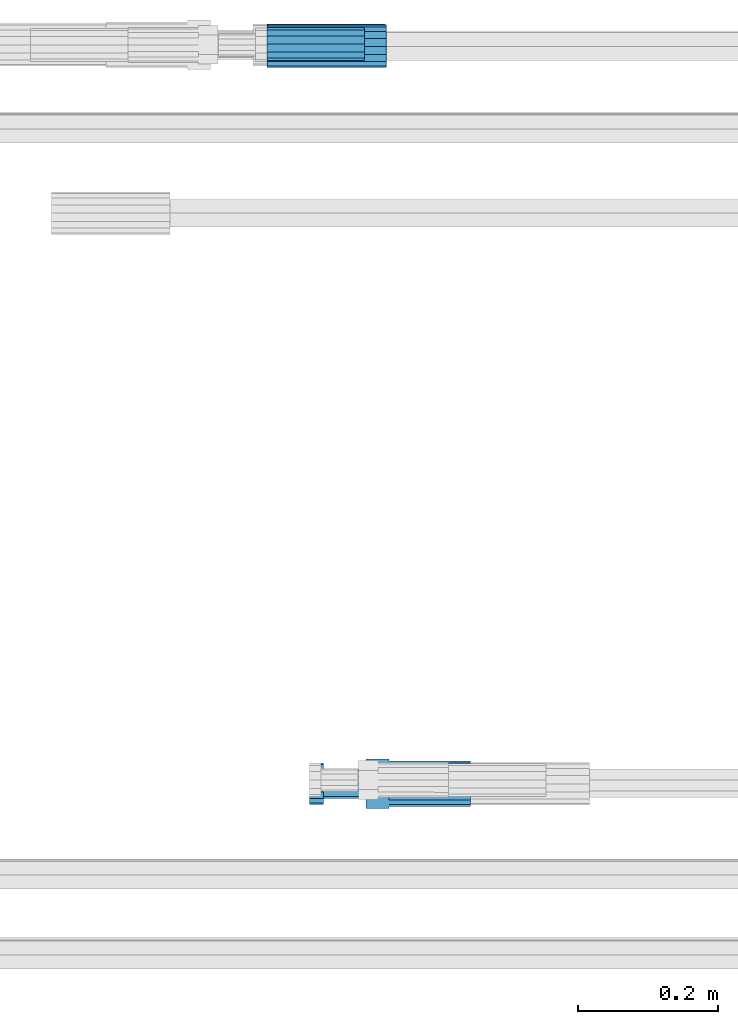
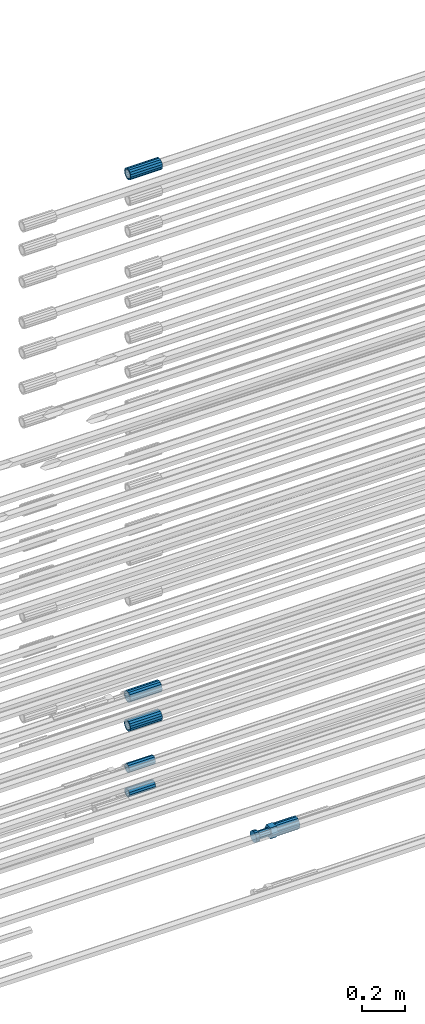
# One storey, part 11 of 119: 6 beams.
"""IFC2X3 building model written with IfcOpenShell, lengths in millimetres."""

from ifc_helpers import new_model, si_unit, frame, origin_with_axes, place, context, subcontext, project, spatial, faceted_brep, material, type_object, element, save


model = new_model("IFC2X3")

# Units and contexts
model_context = context("Model", 3, precision=1e-05, world=origin_with_axes())
body_context = subcontext(model_context, "Body", "Model", "MODEL_VIEW")
ifc_project = project(units=[si_unit("LENGTHUNIT", "METRE", prefix="MILLI"), si_unit("AREAUNIT", "SQUARE_METRE"), si_unit("VOLUMEUNIT", "CUBIC_METRE"), si_unit("MASSUNIT", "GRAM", prefix="KILO"), si_unit("TIMEUNIT", "SECOND"), si_unit("PLANEANGLEUNIT", "RADIAN"), si_unit("SOLIDANGLEUNIT", "STERADIAN"), si_unit("THERMODYNAMICTEMPERATUREUNIT", "DEGREE_CELSIUS"), si_unit("LUMINOUSINTENSITYUNIT", "LUMEN")], contexts=[model_context])

# Site, building, storey
site_placement = place(None, origin_with_axes())
site = spatial("IfcSite", under=ifc_project, at=site_placement, CompositionType="ELEMENT")
building_placement = place(site_placement, origin_with_axes())
building = spatial("IfcBuilding", under=site, at=building_placement, Name="Undefined", CompositionType="ELEMENT")
storey_placement = place(building_placement, origin_with_axes())
storey = spatial("IfcBuildingStorey", under=building, at=storey_placement, Name="Undefined", CompositionType="ELEMENT", Elevation=0.0)

# Beams
ifc_material = material(Name="STEEL/S275")
beam_type_1 = type_object("IfcBeamType", PredefinedType="NOTDEFINED")
beam_1_placement = place(storey_placement, frame((2032019.02007889, 6206399.98994599, 19251.9793079297), z_axis=(0.0, 0.0, 1.0), x_axis=(-0.99999999999998, 1.98000110685822e-07, 0.0)))
element("IfcBeam", 1, at=beam_1_placement, inside=storey, type_object=beam_type_1, material=ifc_material, Name="AG40N", context=body_context, shape_type="Brep", body=[
    faceted_brep([(1.62981450557709e-09, -23.4999999990687, 0.0), (7.45058059692383e-09, -21.7111690142192, 8.99306066057534), (170.000002125278, -21.711168999318, 8.99306066022245), (170.000002127141, -23.4999999844003, -3.66071617463604e-10), (4.65661287307739e-09, -16.6170093587134, 16.6170093578889), (170.000002122484, -16.6170093440451, 16.6170093575288), (1.86264514923096e-09, -8.99306066217832, 21.7111690140277), (170.000002118759, -8.99306064750999, 21.7111690136603), (2.3283064365387e-10, 9.31322574615479e-10, 23.5), (170.000002114102, 1.28056854009628e-08, 23.4999999996485), (-6.51925802230835e-09, 8.99306065868586, 21.7111690140241), (170.00000211224, 8.99306067335419, 21.7111690136639), (-7.45058059692383e-09, 16.6170093561523, 16.6170093578853), (170.000002109446, 16.6170093708206, 16.6170093575324), (-9.31322574615479e-09, 21.711169013055, 8.99306066057534), (170.000002108514, 21.7111690277234, 8.99306066022245), (-1.16415321826935e-09, 23.5000000009313, 0.0), (170.000002108514, 23.5000000144355, -3.66071617463604e-10), (-8.38190317153931e-09, 21.7111690151505, -8.99306066059444), (170.000002110377, 21.7111690300517, -8.9930606609546), (-5.58793544769287e-09, 16.6170093598776, -16.6170093579008), (170.000002113171, 16.6170093745459, -16.6170093582609), (-9.31322574615479e-10, 8.99306066334248, -21.7111690140396), (170.000002115965, 8.99306067801081, -21.7111690143961), (2.3283064365387e-10, 9.31322574615479e-10, -23.5), (170.00000211969, 1.7927959561348e-08, -23.5000000003843), (5.58793544769287e-09, -8.99306065752171, -21.7111690140396), (170.000002123415, -8.99306064285338, -21.7111690143961), (8.38190317153931e-09, -16.6170093549881, -16.6170093579008), (170.000002125278, -16.6170093403198, -16.6170093582646), (9.31322574615479e-09, -21.7111690121237, -8.99306066059444), (170.000002127141, -21.7111689972226, -8.9930606609546), (1.11758708953857e-08, -30.4999999990687, -9.54969436861575e-12), (1.30385160446167e-08, -28.1783257392235, -11.6718446871514), (170.000002129003, -28.1783257243223, -11.6718446875116), (170.000002129935, -30.4999999841675, -3.66071617463604e-10), (1.02445483207703e-08, -21.5667568228673, -21.5667568262129), (170.000002128072, -21.566756808199, -21.5667568265694), (7.45058059692383e-09, -11.6718446831219, -28.1783257416196), (170.000002125278, -11.6718446684536, -28.1783257419834), (3.72529029846191e-09, 3.95812094211578e-09, -30.5000000000277), (170.00000211969, 1.83936208486557e-08, -30.5000000003879), (-9.31322574615479e-10, 11.6718446905725, -28.1783257416232), (170.000002115965, 11.6718447052408, -28.1783257419797), (-6.51925802230835e-09, 21.5667568286881, -21.5667568262093), (170.000002110377, 21.5667568433564, -21.5667568265694), (-9.31322574615479e-09, 28.178325742716, -11.6718446871478), (170.000002108514, 28.1783257573843, -11.6718446875079), (-1.21071934700012e-08, 30.5, -5.91171556152403e-12), (170.000002106652, 30.5000000144355, -3.62433638656512e-10), (-1.21071934700012e-08, 28.1783257401548, 11.6718446871359), (170.00000210572, 28.1783257548232, 11.6718446867794), (-1.02445483207703e-08, 21.5667568240315, 21.5667568261974), (170.000002107583, 21.566756838467, 21.5667568258409), (-7.45058059692383e-09, 11.671844684286, 28.1783257416041), (170.000002110377, 11.6718446989544, 28.178325741244), (-2.79396772384644e-09, -2.56113708019257e-09, 30.5000000000159), (170.000002114102, 1.18743628263474e-08, 30.4999999996558), (1.86264514923096e-09, -11.6718446896411, 28.1783257416114), (170.000002118759, -11.67184467474, 28.178325741244), (7.45058059692383e-09, -21.5667568275239, 21.5667568261974), (170.000002123415, -21.5667568126228, 21.5667568258373), (1.02445483207703e-08, -28.1783257415518, 11.6718446871359), (170.000002127141, -28.1783257271163, 11.6718446867794)], [[[0, 1, 2, 3]], [[1, 4, 5, 2]], [[4, 6, 7, 5]], [[6, 8, 9, 7]], [[8, 10, 11, 9]], [[10, 12, 13, 11]], [[12, 14, 15, 13]], [[14, 16, 17, 15]], [[16, 18, 19, 17]], [[18, 20, 21, 19]], [[20, 22, 23, 21]], [[22, 24, 25, 23]], [[24, 26, 27, 25]], [[26, 28, 29, 27]], [[28, 30, 31, 29]], [[30, 0, 3, 31]], [[32, 33, 34, 35]], [[33, 36, 37, 34]], [[36, 38, 39, 37]], [[38, 40, 41, 39]], [[40, 42, 43, 41]], [[42, 44, 45, 43]], [[44, 46, 47, 45]], [[46, 48, 49, 47]], [[48, 50, 51, 49]], [[50, 52, 53, 51]], [[52, 54, 55, 53]], [[54, 56, 57, 55]], [[56, 58, 59, 57]], [[58, 60, 61, 59]], [[60, 62, 63, 61]], [[62, 32, 35, 63]], [[37, 39, 41, 43, 45, 47, 49, 51, 53, 55, 57, 59, 61, 63, 35, 34], [5, 7, 9, 11, 13, 15, 17, 19, 21, 23, 25, 27, 29, 31, 3, 2]], [[62, 60, 58, 56, 54, 52, 50, 48, 46, 44, 42, 40, 38, 36, 33, 32], [30, 28, 26, 24, 22, 20, 18, 16, 14, 12, 10, 8, 6, 4, 1, 0]]]),
])
beam_2_placement = place(storey_placement, frame((2032019.02007888, 6206401.47994599, 19414.9893081764), z_axis=(0.0, 0.0, 1.0), x_axis=(-0.99999999999998, 1.98000110685822e-07, 0.0)))
element("IfcBeam", 2, at=beam_2_placement, inside=storey, type_object=beam_type_1, material=ifc_material, Name="AG40N", context=body_context, shape_type="Brep", body=[
    faceted_brep([(1.62981450557709e-09, -23.4999999990687, 0.0), (7.45058059692383e-09, -21.7111690142192, 8.99306066057534), (170.000002125278, -21.711168999318, 8.99306066022245), (170.000002127141, -23.4999999844003, -3.66071617463604e-10), (4.65661287307739e-09, -16.6170093587134, 16.6170093578889), (170.000002122484, -16.6170093440451, 16.6170093575288), (1.86264514923096e-09, -8.99306066217832, 21.7111690140277), (170.000002118759, -8.99306064750999, 21.7111690136603), (2.3283064365387e-10, 9.31322574615479e-10, 23.5), (170.000002114102, 1.28056854009628e-08, 23.4999999996485), (-6.51925802230835e-09, 8.99306065868586, 21.7111690140241), (170.00000211224, 8.99306067335419, 21.7111690136639), (-7.45058059692383e-09, 16.6170093561523, 16.6170093578853), (170.000002109446, 16.6170093708206, 16.6170093575324), (-9.31322574615479e-09, 21.711169013055, 8.99306066057534), (170.000002108514, 21.7111690277234, 8.99306066022245), (-1.16415321826935e-09, 23.5000000009313, 0.0), (170.000002108514, 23.5000000144355, -3.66071617463604e-10), (-8.38190317153931e-09, 21.7111690151505, -8.99306066059444), (170.000002110377, 21.7111690300517, -8.9930606609546), (-5.58793544769287e-09, 16.6170093598776, -16.6170093579008), (170.000002113171, 16.6170093745459, -16.6170093582609), (-9.31322574615479e-10, 8.99306066334248, -21.7111690140396), (170.000002115965, 8.99306067801081, -21.7111690143961), (2.3283064365387e-10, 9.31322574615479e-10, -23.5), (170.00000211969, 1.7927959561348e-08, -23.5000000003843), (5.58793544769287e-09, -8.99306065752171, -21.7111690140396), (170.000002123415, -8.99306064285338, -21.7111690143961), (8.38190317153931e-09, -16.6170093549881, -16.6170093579008), (170.000002125278, -16.6170093403198, -16.6170093582646), (9.31322574615479e-09, -21.7111690121237, -8.99306066059444), (170.000002127141, -21.7111689972226, -8.9930606609546), (1.11758708953857e-08, -30.4999999990687, -9.54969436861575e-12), (1.30385160446167e-08, -28.1783257392235, -11.6718446871514), (170.000002129003, -28.1783257243223, -11.6718446875116), (170.000002129935, -30.4999999841675, -3.66071617463604e-10), (1.02445483207703e-08, -21.5667568228673, -21.5667568262129), (170.000002128072, -21.566756808199, -21.5667568265694), (7.45058059692383e-09, -11.6718446831219, -28.1783257416196), (170.000002125278, -11.6718446684536, -28.1783257419834), (3.72529029846191e-09, 3.95812094211578e-09, -30.5000000000277), (170.00000211969, 1.83936208486557e-08, -30.5000000003879), (-9.31322574615479e-10, 11.6718446905725, -28.1783257416232), (170.000002115965, 11.6718447052408, -28.1783257419797), (-6.51925802230835e-09, 21.5667568286881, -21.5667568262093), (170.000002110377, 21.5667568433564, -21.5667568265694), (-9.31322574615479e-09, 28.178325742716, -11.6718446871478), (170.000002108514, 28.1783257573843, -11.6718446875079), (-1.21071934700012e-08, 30.5, -5.91171556152403e-12), (170.000002106652, 30.5000000144355, -3.62433638656512e-10), (-1.21071934700012e-08, 28.1783257401548, 11.6718446871359), (170.00000210572, 28.1783257548232, 11.6718446867794), (-1.02445483207703e-08, 21.5667568240315, 21.5667568261974), (170.000002107583, 21.566756838467, 21.5667568258409), (-7.45058059692383e-09, 11.671844684286, 28.1783257416041), (170.000002110377, 11.6718446989544, 28.178325741244), (-2.79396772384644e-09, -2.56113708019257e-09, 30.5000000000159), (170.000002114102, 1.18743628263474e-08, 30.4999999996558), (1.86264514923096e-09, -11.6718446896411, 28.1783257416114), (170.000002118759, -11.67184467474, 28.178325741244), (7.45058059692383e-09, -21.5667568275239, 21.5667568261974), (170.000002123415, -21.5667568126228, 21.5667568258373), (1.02445483207703e-08, -28.1783257415518, 11.6718446871359), (170.000002127141, -28.1783257271163, 11.6718446867794)], [[[0, 1, 2, 3]], [[1, 4, 5, 2]], [[4, 6, 7, 5]], [[6, 8, 9, 7]], [[8, 10, 11, 9]], [[10, 12, 13, 11]], [[12, 14, 15, 13]], [[14, 16, 17, 15]], [[16, 18, 19, 17]], [[18, 20, 21, 19]], [[20, 22, 23, 21]], [[22, 24, 25, 23]], [[24, 26, 27, 25]], [[26, 28, 29, 27]], [[28, 30, 31, 29]], [[30, 0, 3, 31]], [[32, 33, 34, 35]], [[33, 36, 37, 34]], [[36, 38, 39, 37]], [[38, 40, 41, 39]], [[40, 42, 43, 41]], [[42, 44, 45, 43]], [[44, 46, 47, 45]], [[46, 48, 49, 47]], [[48, 50, 51, 49]], [[50, 52, 53, 51]], [[52, 54, 55, 53]], [[54, 56, 57, 55]], [[56, 58, 59, 57]], [[58, 60, 61, 59]], [[60, 62, 63, 61]], [[62, 32, 35, 63]], [[37, 39, 41, 43, 45, 47, 49, 51, 53, 55, 57, 59, 61, 63, 35, 34], [5, 7, 9, 11, 13, 15, 17, 19, 21, 23, 25, 27, 29, 31, 3, 2]], [[62, 60, 58, 56, 54, 52, 50, 48, 46, 44, 42, 40, 38, 36, 33, 32], [30, 28, 26, 24, 22, 20, 18, 16, 14, 12, 10, 8, 6, 4, 1, 0]]]),
])
beam_3_placement = place(storey_placement, frame((2032020.00007889, 6206399.98994599, 22359.9893060789), z_axis=(0.0, 0.0, 1.0), x_axis=(-0.99999999999998, 1.98000110685822e-07, 0.0)))
element("IfcBeam", 3, at=beam_3_placement, inside=storey, type_object=beam_type_1, material=ifc_material, Name="AG40N", context=body_context, shape_type="Brep", body=[
    faceted_brep([(1.62981450557709e-09, -23.4999999990687, 0.0), (7.45058059692383e-09, -21.7111690142192, 8.99306066057534), (170.000002125278, -21.711168999318, 8.99306066022245), (170.000002127141, -23.4999999844003, -3.66071617463604e-10), (4.65661287307739e-09, -16.6170093587134, 16.6170093578889), (170.000002122484, -16.6170093440451, 16.6170093575288), (1.86264514923096e-09, -8.99306066217832, 21.7111690140277), (170.000002118759, -8.99306064750999, 21.7111690136603), (2.3283064365387e-10, 9.31322574615479e-10, 23.5), (170.000002114102, 1.28056854009628e-08, 23.4999999996485), (-6.51925802230835e-09, 8.99306065868586, 21.7111690140241), (170.00000211224, 8.99306067335419, 21.7111690136639), (-7.45058059692383e-09, 16.6170093561523, 16.6170093578853), (170.000002109446, 16.6170093708206, 16.6170093575324), (-9.31322574615479e-09, 21.711169013055, 8.99306066057534), (170.000002108514, 21.7111690277234, 8.99306066022245), (-1.16415321826935e-09, 23.5000000009313, 0.0), (170.000002108514, 23.5000000144355, -3.66071617463604e-10), (-8.38190317153931e-09, 21.7111690151505, -8.99306066059444), (170.000002110377, 21.7111690300517, -8.9930606609546), (-5.58793544769287e-09, 16.6170093598776, -16.6170093579008), (170.000002113171, 16.6170093745459, -16.6170093582609), (-9.31322574615479e-10, 8.99306066334248, -21.7111690140396), (170.000002115965, 8.99306067801081, -21.7111690143961), (2.3283064365387e-10, 9.31322574615479e-10, -23.5), (170.00000211969, 1.7927959561348e-08, -23.5000000003843), (5.58793544769287e-09, -8.99306065752171, -21.7111690140396), (170.000002123415, -8.99306064285338, -21.7111690143961), (8.38190317153931e-09, -16.6170093549881, -16.6170093579008), (170.000002125278, -16.6170093403198, -16.6170093582646), (9.31322574615479e-09, -21.7111690121237, -8.99306066059444), (170.000002127141, -21.7111689972226, -8.9930606609546), (1.11758708953857e-08, -30.4999999990687, -9.54969436861575e-12), (1.30385160446167e-08, -28.1783257392235, -11.6718446871514), (170.000002129003, -28.1783257243223, -11.6718446875116), (170.000002129935, -30.4999999841675, -3.66071617463604e-10), (1.02445483207703e-08, -21.5667568228673, -21.5667568262129), (170.000002128072, -21.566756808199, -21.5667568265694), (7.45058059692383e-09, -11.6718446831219, -28.1783257416196), (170.000002125278, -11.6718446684536, -28.1783257419834), (3.72529029846191e-09, 3.95812094211578e-09, -30.5000000000277), (170.00000211969, 1.83936208486557e-08, -30.5000000003879), (-9.31322574615479e-10, 11.6718446905725, -28.1783257416232), (170.000002115965, 11.6718447052408, -28.1783257419797), (-6.51925802230835e-09, 21.5667568286881, -21.5667568262093), (170.000002110377, 21.5667568433564, -21.5667568265694), (-9.31322574615479e-09, 28.178325742716, -11.6718446871478), (170.000002108514, 28.1783257573843, -11.6718446875079), (-1.21071934700012e-08, 30.5, -5.91171556152403e-12), (170.000002106652, 30.5000000144355, -3.62433638656512e-10), (-1.21071934700012e-08, 28.1783257401548, 11.6718446871359), (170.00000210572, 28.1783257548232, 11.6718446867794), (-1.02445483207703e-08, 21.5667568240315, 21.5667568261974), (170.000002107583, 21.566756838467, 21.5667568258409), (-7.45058059692383e-09, 11.671844684286, 28.1783257416041), (170.000002110377, 11.6718446989544, 28.178325741244), (-2.79396772384644e-09, -2.56113708019257e-09, 30.5000000000159), (170.000002114102, 1.18743628263474e-08, 30.4999999996558), (1.86264514923096e-09, -11.6718446896411, 28.1783257416114), (170.000002118759, -11.67184467474, 28.178325741244), (7.45058059692383e-09, -21.5667568275239, 21.5667568261974), (170.000002123415, -21.5667568126228, 21.5667568258373), (1.02445483207703e-08, -28.1783257415518, 11.6718446871359), (170.000002127141, -28.1783257271163, 11.6718446867794)], [[[0, 1, 2, 3]], [[1, 4, 5, 2]], [[4, 6, 7, 5]], [[6, 8, 9, 7]], [[8, 10, 11, 9]], [[10, 12, 13, 11]], [[12, 14, 15, 13]], [[14, 16, 17, 15]], [[16, 18, 19, 17]], [[18, 20, 21, 19]], [[20, 22, 23, 21]], [[22, 24, 25, 23]], [[24, 26, 27, 25]], [[26, 28, 29, 27]], [[28, 30, 31, 29]], [[30, 0, 3, 31]], [[32, 33, 34, 35]], [[33, 36, 37, 34]], [[36, 38, 39, 37]], [[38, 40, 41, 39]], [[40, 42, 43, 41]], [[42, 44, 45, 43]], [[44, 46, 47, 45]], [[46, 48, 49, 47]], [[48, 50, 51, 49]], [[50, 52, 53, 51]], [[52, 54, 55, 53]], [[54, 56, 57, 55]], [[56, 58, 59, 57]], [[58, 60, 61, 59]], [[60, 62, 63, 61]], [[62, 32, 35, 63]], [[37, 39, 41, 43, 45, 47, 49, 51, 53, 55, 57, 59, 61, 63, 35, 34], [5, 7, 9, 11, 13, 15, 17, 19, 21, 23, 25, 27, 29, 31, 3, 2]], [[62, 60, 58, 56, 54, 52, 50, 48, 46, 44, 42, 40, 38, 36, 33, 32], [30, 28, 26, 24, 22, 20, 18, 16, 14, 12, 10, 8, 6, 4, 1, 0]]]),
])
beam_type_2 = type_object("IfcBeamType", Name="ROD65", PredefinedType="NOTDEFINED")
beam_4_placement = place(storey_placement, frame((2032140.98007889, 6205343.08994599, 19244.4893061782), z_axis=(0.0, 0.0, 1.0), x_axis=(-0.99999999999998, 1.98000110685822e-07, 0.0)))
element("IfcBeam", 4, at=beam_4_placement, inside=storey, type_object=beam_type_2, material=ifc_material, Name="AGB40", ObjectType="ROD65", context=body_context, shape_type="Brep", body=[
    faceted_brep([(116.999999999069, 17.8249999252148, 30.8738056446964), (116.999999998137, 22.0056957420893, 23.632628078838), (116.999999999069, 12.4372115600854, 30.0260848066173), (116.999999999069, 8.17543111252598, 30.8738056446964), (117.000000000931, -17.8250000746921, 30.8738056446964), (150.200000001118, -17.8250000723638, 30.8738056446964), (150.199999999255, 17.8249999275431, 30.8738056446964), (117.000000000931, -8.17543109622784, 30.8738056446964), (117.000000001863, -22.0056959956419, 23.6326278985034), (117.000000000931, -12.4372115437873, 30.0260848066173), (117.000000001863, -35.6500000746455, -2.18278728425503e-10), (150.200000002049, -35.6500000723172, -2.18278728425503e-10), (117.000000001863, -30.8443149488885, 8.32369080289209), (117.000000001863, -30.8443149488885, -8.32369080355784), (117.000000002794, -32.4999999918509, 0.0), (117.000000000931, -17.8250000746921, -30.873805645133), (150.200000001118, -17.8250000723638, -30.873805645133), (117.000000001863, -22.0056959961075, -23.6326278982269), (117.000000000931, -8.17543109389953, -30.873805645133), (117.000000000931, -12.4372115437873, -30.0260848066173), (116.999999999069, 17.8249999252148, -30.873805645133), (150.199999999255, 17.8249999275431, -30.873805645133), (116.999999999069, 8.17543111019768, -30.873805645133), (116.999999999069, 12.4372115600854, -30.0260848066173), (116.999999998137, 22.005695742555, -23.6326280785652), (116.999999998137, 35.6499999251682, -2.18278728425503e-10), (150.199999998324, 35.6499999277294, -2.18278728425503e-10), (116.999999998137, 30.8443150522653, -8.32369036550881), (116.999999997206, 32.5000000081491, 0.0), (116.999999998137, 30.8443150522653, 8.32369036483942), (1.86264514923096e-09, -22.9809703885112, 22.9809703885621), (1.86264514923096e-09, -30.0260848065373, 12.4372115518672), (117.000000001863, -30.0260847983882, 12.4372115518672), (117.000000001863, -22.9809703803621, 22.9809703885621), (-1.86264514923096e-09, 22.9809703885112, -22.9809703885621), (-1.86264514923096e-09, 30.0260848065373, -12.4372115518672), (116.999999998137, 30.0260848146863, -12.4372115518672), (116.999999998137, 22.9809703966603, -22.9809703885621), (1.86264514923096e-09, -30.0260848065373, -12.4372115518672), (1.86264514923096e-09, -22.9809703885112, -22.9809703885621), (117.000000001863, -22.9809703803621, -22.9809703885621), (117.000000001863, -30.0260847983882, -12.4372115518672), (9.31322574615479e-10, -12.4372115519363, 30.0260848066173), (0.0, 0.0, 32.5), (-9.31322574615479e-10, 12.4372115519363, 30.0260848066173), (-1.86264514923096e-09, 22.9809703885112, 22.9809703885621), (-1.86264514923096e-09, 30.0260848065373, 12.4372115518672), (-2.79396772384644e-09, 32.5, 0.0), (-9.31322574615479e-10, 12.4372115519363, -30.0260848066173), (0.0, 0.0, -32.5), (9.31322574615479e-10, -12.4372115519363, -30.0260848066173), (2.79396772384644e-09, -32.5, 0.0), (116.999999998137, 22.9809703966603, 22.9809703885621), (116.999999998137, 30.0260848146863, 12.4372115518672), (117.0, 8.14907252788544e-09, -32.5), (117.0, 8.14907252788544e-09, 32.5), (150.200000000186, -10.5000000959262, 18.1865334791873), (150.199999999255, -9.59262251853943e-08, 20.9999999997126), (150.199999998324, 10.4999999040738, 18.1865334791873), (150.199999997392, 18.1865333835594, 10.4999999997126), (150.199999997392, 20.9999999040738, -2.87400325760245e-10), (150.199999997392, 18.1865333835594, -10.5000000002874), (150.199999998324, 10.4999999040738, -18.1865334797621), (150.199999999255, -9.59262251853943e-08, -21.0000000002874), (150.200000000186, -10.5000000959262, -18.1865334797621), (150.200000000186, -18.1865335754119, -10.5000000002874), (150.200000001118, -21.0000000959262, -2.87400325760245e-10), (150.200000000186, -18.1865335754119, 10.4999999997126), (210.979999999516, 10.4999999082647, 18.1865334791873), (210.979999999516, -9.17352735996246e-08, 20.9999999997126), (210.979999997653, 18.1865333877504, 10.4999999997126), (210.979999997653, 20.9999999082647, -2.87400325760245e-10), (210.979999997653, 18.1865333877504, -10.5000000002874), (210.979999999516, 10.4999999082647, -18.1865334797621), (210.979999999516, -9.17352735996246e-08, -21.0000000002874), (210.979999999516, -10.5000000917353, -18.1865334797621), (210.980000000447, -18.1865335712209, -10.5000000002874), (210.980000001378, -21.0000000917353, -2.87400325760245e-10), (210.980000000447, -18.1865335712209, 10.4999999997126), (210.979999999516, -10.5000000917353, 18.1865334791873), (211.001368402503, -27.7269939335529, -11.4911163272045), (211.003082515672, -21.2238095656503, -21.2238154190527), (231.002518340945, -21.2131946226582, -21.2132004554769), (231.000804228708, -27.7163789905608, -11.4805013636287), (211.001368415542, -11.4911086384673, -27.7269970399575), (231.000804241747, -11.4804936954752, -27.7163820763781), (210.996487061493, -0.0106066407170147, -30.0106107396168), (230.995922887698, 8.30227509140968e-06, -29.999995776041), (210.98918159306, 11.4698940692469, -27.7269970332745), (230.988617419265, 11.4805090120062, -27.7163820696951), (210.980564201251, 21.2025913291145, -21.2238154067054), (230.980000027455, 21.2132062721066, -21.2132004431296), (210.971946807578, 27.7057702087332, -11.4911163110701), (230.971382633783, 27.7163851517253, -11.4805013474943), (210.964641331695, 29.9893806746695, -0.0106149565435771), (230.9640771579, 29.9999956176616, 7.03221303410828e-09), (210.959759964608, 27.7057637346443, 11.4698863966551), (230.959195790812, 27.7163786776364, 11.4805013602345), (210.958045851439, 21.2025793667417, 21.2025854885032), (230.957481677644, 21.2131943097338, 21.2132004520827), (210.959759951569, 11.4698784395587, 27.705767109408), (230.959195776843, 11.4804933823179, 27.7163820729838), (210.964641305618, -0.0106235581915826, 29.9893808090674), (230.964077131823, -8.61519947648048e-06, 29.9999957726432), (210.971946774051, -11.4911242681555, 27.7057671027251), (230.971382599324, -11.4805093251634, 27.7163820663009), (210.98056416586, -21.2238215280231, 21.2025854761559), (230.979999991134, -21.2132065852638, 21.2132004397354), (210.989181559533, -27.7270004076418, 11.4698863805206), (230.988617384806, -27.7163854646496, 11.4805013441), (210.996487035416, -30.0106108735781, -0.0106149740058754), (230.995922861621, -29.999995930586, -1.04300852399319e-08)], [[[0, 1, 2, 3]], [[4, 5, 6, 0, 3, 7]], [[8, 4, 7, 9]], [[10, 11, 5, 4, 8, 12]], [[13, 10, 12, 14]], [[15, 16, 11, 10, 13, 17]], [[18, 15, 17, 19]], [[20, 21, 16, 15, 18, 22]], [[20, 22, 23, 24]], [[25, 26, 21, 20, 24, 27]], [[25, 27, 28, 29]], [[30, 31, 32, 33]], [[34, 35, 36, 37]], [[38, 39, 40, 41]], [[31, 30, 42, 43, 44, 45, 46, 47, 35, 34, 48, 49, 50, 39, 38, 51]], [[46, 45, 52, 53]], [[28, 47, 46, 53, 29]], [[27, 36, 35, 47, 28]], [[24, 37, 36, 27]], [[23, 48, 34, 37, 24]], [[22, 54, 49, 48, 23]], [[18, 54, 22]], [[19, 50, 49, 54, 18]], [[17, 40, 39, 50, 19]], [[13, 41, 40, 17]], [[14, 51, 38, 41, 13]], [[12, 32, 31, 51, 14]], [[8, 33, 32, 12]], [[9, 42, 30, 33, 8]], [[7, 55, 43, 42, 9]], [[3, 55, 7]], [[2, 44, 43, 55, 3]], [[1, 52, 45, 44, 2]], [[29, 53, 52, 1]], [[0, 6, 26, 25, 29, 1]], [[5, 11, 16, 21, 26, 6], [56, 57, 58, 59, 60, 61, 62, 63, 64, 65, 66, 67]], [[68, 58, 57, 69]], [[70, 59, 58, 68]], [[71, 60, 59, 70]], [[72, 61, 60, 71]], [[73, 62, 61, 72]], [[74, 63, 62, 73]], [[75, 64, 63, 74]], [[76, 65, 64, 75]], [[77, 66, 65, 76]], [[78, 67, 66, 77]], [[79, 56, 67, 78]], [[69, 57, 56, 79]], [[80, 81, 82, 83]], [[81, 84, 85, 82]], [[84, 86, 87, 85]], [[86, 88, 89, 87]], [[88, 90, 91, 89]], [[90, 92, 93, 91]], [[92, 94, 95, 93]], [[94, 96, 97, 95]], [[96, 98, 99, 97]], [[98, 100, 101, 99]], [[100, 102, 103, 101]], [[102, 104, 105, 103]], [[104, 106, 107, 105]], [[106, 108, 109, 107]], [[108, 110, 111, 109]], [[82, 85, 87, 89, 91, 93, 95, 97, 99, 101, 103, 105, 107, 109, 111, 83]], [[110, 80, 83, 111]], [[108, 106, 104, 102, 100, 98, 96, 94, 92, 90, 88, 86, 84, 81, 80, 110], [78, 77, 76, 75, 74, 73, 72, 71, 70, 68, 69, 79]]]),
])
beam_type_3 = type_object("IfcBeamType", PredefinedType="NOTDEFINED")
beam_5_placement = place(storey_placement, frame((2031849.02007889, 6206403.47994599, 18871.4893037275), z_axis=(0.0, 0.0, 1.0), x_axis=(1.0, 0.0, 0.0)))
element("IfcBeam", 5, at=beam_5_placement, inside=storey, type_object=beam_type_3, material=ifc_material, Name="AG32N", context=body_context, shape_type="Brep", body=[
    faceted_brep([(1.39698386192322e-09, -18.4999999990687, 0.0), (1.16415321826935e-09, -16.0214699693024, 9.25), (140.000000001164, -16.0214699935168, 9.25), (140.000000001397, -18.5000000232831, 0.0), (6.98491930961609e-10, -9.24999999906868, 16.0214699700118), (140.000000000698, -9.25000002328306, 16.0214699700118), (2.3283064365387e-10, 9.31322574615479e-10, 18.5), (140.000000000233, -2.3283064365387e-08, 18.5), (-2.3283064365387e-10, 9.25000000093132, 16.0214699700118), (139.999999999767, 9.24999997671694, 16.0214699700118), (-6.98491930961609e-10, 16.0214699711651, 9.25), (139.999999999302, 16.0214699469507, 9.25), (-9.31322574615479e-10, 18.5000000009313, 0.0), (139.999999999069, 18.4999999767169, 0.0), (-6.98491930961609e-10, 16.0214699711651, -9.25), (139.999999999302, 16.0214699469507, -9.25), (-2.3283064365387e-10, 9.25000000093132, -16.0214699700118), (139.999999999767, 9.24999997671694, -16.0214699700118), (2.3283064365387e-10, 9.31322574615479e-10, -18.5), (140.000000000233, -2.3283064365387e-08, -18.5), (6.98491930961609e-10, -9.24999999906868, -16.0214699700118), (140.000000000698, -9.25000002328306, -16.0214699700118), (1.16415321826935e-09, -16.0214699693024, -9.25), (140.000000001164, -16.0214699935168, -9.25), (1.62981450557709e-09, -23.4999999990687, 0.0), (1.39698386192322e-09, -20.3515969878063, -11.75), (140.000000001397, -20.3515970120206, -11.75), (140.00000000163, -23.5000000232831, 0.0), (9.31322574615479e-10, -11.7499999990687, -20.351596988934), (140.000000000931, -11.7500000232831, -20.351596988934), (2.3283064365387e-10, 9.31322574615479e-10, -23.5), (140.000000000233, -2.3283064365387e-08, -23.5), (-4.65661287307739e-10, 11.7500000009313, -20.351596988934), (139.999999999534, 11.7499999767169, -20.351596988934), (-9.31322574615479e-10, 20.3515969896689, -11.75), (139.999999999069, 20.3515969654545, -11.75), (-1.16415321826935e-09, 23.5000000009313, 0.0), (139.999999998836, 23.4999999767169, 0.0), (-9.31322574615479e-10, 20.3515969896689, 11.75), (139.999999999069, 20.3515969654545, 11.75), (-4.65661287307739e-10, 11.7500000009313, 20.351596988934), (139.999999999534, 11.7499999767169, 20.351596988934), (2.3283064365387e-10, 9.31322574615479e-10, 23.5), (140.000000000233, -2.3283064365387e-08, 23.5), (9.31322574615479e-10, -11.7499999990687, 20.351596988934), (140.000000000931, -11.7500000232831, 20.351596988934), (1.39698386192322e-09, -20.3515969878063, 11.75), (140.000000001397, -20.3515970120206, 11.75)], [[[0, 1, 2, 3]], [[1, 4, 5, 2]], [[4, 6, 7, 5]], [[6, 8, 9, 7]], [[8, 10, 11, 9]], [[10, 12, 13, 11]], [[12, 14, 15, 13]], [[14, 16, 17, 15]], [[16, 18, 19, 17]], [[18, 20, 21, 19]], [[20, 22, 23, 21]], [[22, 0, 3, 23]], [[24, 25, 26, 27]], [[25, 28, 29, 26]], [[28, 30, 31, 29]], [[30, 32, 33, 31]], [[32, 34, 35, 33]], [[34, 36, 37, 35]], [[36, 38, 39, 37]], [[38, 40, 41, 39]], [[40, 42, 43, 41]], [[42, 44, 45, 43]], [[44, 46, 47, 45]], [[46, 24, 27, 47]], [[29, 31, 33, 35, 37, 39, 41, 43, 45, 47, 27, 26], [5, 7, 9, 11, 13, 15, 17, 19, 21, 23, 3, 2]], [[46, 44, 42, 40, 38, 36, 34, 32, 30, 28, 25, 24], [22, 20, 18, 16, 14, 12, 10, 8, 6, 4, 1, 0]]]),
])
beam_6_placement = place(storey_placement, frame((2031849.02007888, 6206403.47994599, 19010.2693037275), z_axis=(0.0, 0.0, 1.0), x_axis=(1.0, 0.0, 0.0)))
element("IfcBeam", 6, at=beam_6_placement, inside=storey, type_object=beam_type_3, material=ifc_material, Name="AG32N", context=body_context, shape_type="Brep", body=[
    faceted_brep([(1.39698386192322e-09, -18.4999999990687, 0.0), (1.16415321826935e-09, -16.0214699693024, 9.25), (140.000000001164, -16.0214699935168, 9.25), (140.000000001397, -18.5000000232831, 0.0), (6.98491930961609e-10, -9.24999999906868, 16.0214699700118), (140.000000000698, -9.25000002328306, 16.0214699700118), (2.3283064365387e-10, 9.31322574615479e-10, 18.5), (140.000000000233, -2.3283064365387e-08, 18.5), (-2.3283064365387e-10, 9.25000000093132, 16.0214699700118), (139.999999999767, 9.24999997671694, 16.0214699700118), (-6.98491930961609e-10, 16.0214699711651, 9.25), (139.999999999302, 16.0214699469507, 9.25), (-9.31322574615479e-10, 18.5000000009313, 0.0), (139.999999999069, 18.4999999767169, 0.0), (-6.98491930961609e-10, 16.0214699711651, -9.25), (139.999999999302, 16.0214699469507, -9.25), (-2.3283064365387e-10, 9.25000000093132, -16.0214699700118), (139.999999999767, 9.24999997671694, -16.0214699700118), (2.3283064365387e-10, 9.31322574615479e-10, -18.5), (140.000000000233, -2.3283064365387e-08, -18.5), (6.98491930961609e-10, -9.24999999906868, -16.0214699700118), (140.000000000698, -9.25000002328306, -16.0214699700118), (1.16415321826935e-09, -16.0214699693024, -9.25), (140.000000001164, -16.0214699935168, -9.25), (1.62981450557709e-09, -23.4999999990687, 0.0), (1.39698386192322e-09, -20.3515969878063, -11.75), (140.000000001397, -20.3515970120206, -11.75), (140.00000000163, -23.5000000232831, 0.0), (9.31322574615479e-10, -11.7499999990687, -20.351596988934), (140.000000000931, -11.7500000232831, -20.351596988934), (2.3283064365387e-10, 9.31322574615479e-10, -23.5), (140.000000000233, -2.3283064365387e-08, -23.5), (-4.65661287307739e-10, 11.7500000009313, -20.351596988934), (139.999999999534, 11.7499999767169, -20.351596988934), (-9.31322574615479e-10, 20.3515969896689, -11.75), (139.999999999069, 20.3515969654545, -11.75), (-1.16415321826935e-09, 23.5000000009313, 0.0), (139.999999998836, 23.4999999767169, 0.0), (-9.31322574615479e-10, 20.3515969896689, 11.75), (139.999999999069, 20.3515969654545, 11.75), (-4.65661287307739e-10, 11.7500000009313, 20.351596988934), (139.999999999534, 11.7499999767169, 20.351596988934), (2.3283064365387e-10, 9.31322574615479e-10, 23.5), (140.000000000233, -2.3283064365387e-08, 23.5), (9.31322574615479e-10, -11.7499999990687, 20.351596988934), (140.000000000931, -11.7500000232831, 20.351596988934), (1.39698386192322e-09, -20.3515969878063, 11.75), (140.000000001397, -20.3515970120206, 11.75)], [[[0, 1, 2, 3]], [[1, 4, 5, 2]], [[4, 6, 7, 5]], [[6, 8, 9, 7]], [[8, 10, 11, 9]], [[10, 12, 13, 11]], [[12, 14, 15, 13]], [[14, 16, 17, 15]], [[16, 18, 19, 17]], [[18, 20, 21, 19]], [[20, 22, 23, 21]], [[22, 0, 3, 23]], [[24, 25, 26, 27]], [[25, 28, 29, 26]], [[28, 30, 31, 29]], [[30, 32, 33, 31]], [[32, 34, 35, 33]], [[34, 36, 37, 35]], [[36, 38, 39, 37]], [[38, 40, 41, 39]], [[40, 42, 43, 41]], [[42, 44, 45, 43]], [[44, 46, 47, 45]], [[46, 24, 27, 47]], [[29, 31, 33, 35, 37, 39, 41, 43, 45, 47, 27, 26], [5, 7, 9, 11, 13, 15, 17, 19, 21, 23, 3, 2]], [[46, 44, 42, 40, 38, 36, 34, 32, 30, 28, 25, 24], [22, 20, 18, 16, 14, 12, 10, 8, 6, 4, 1, 0]]]),
])

save(model, "model.ifc")
